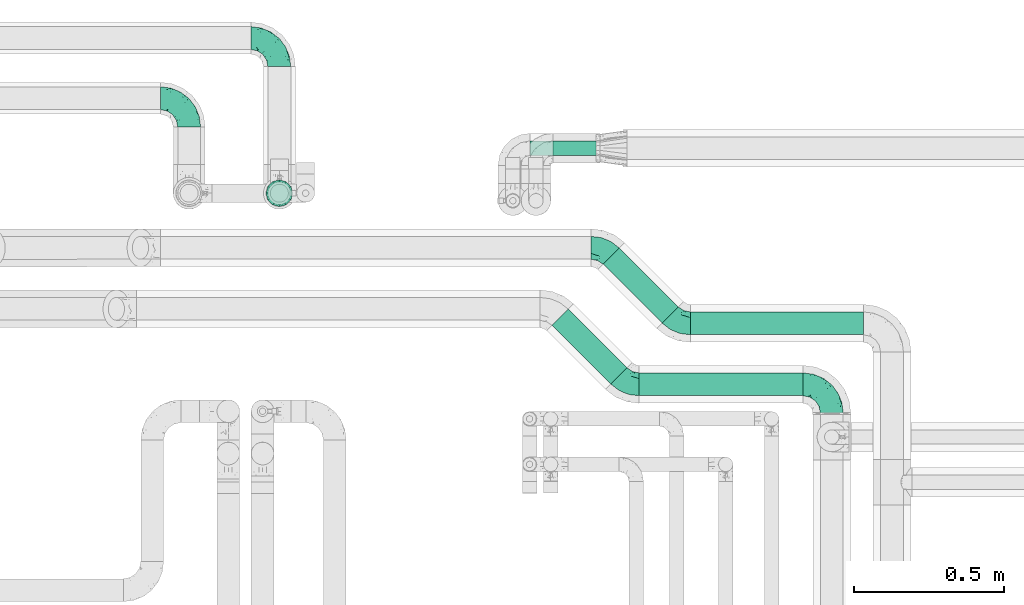
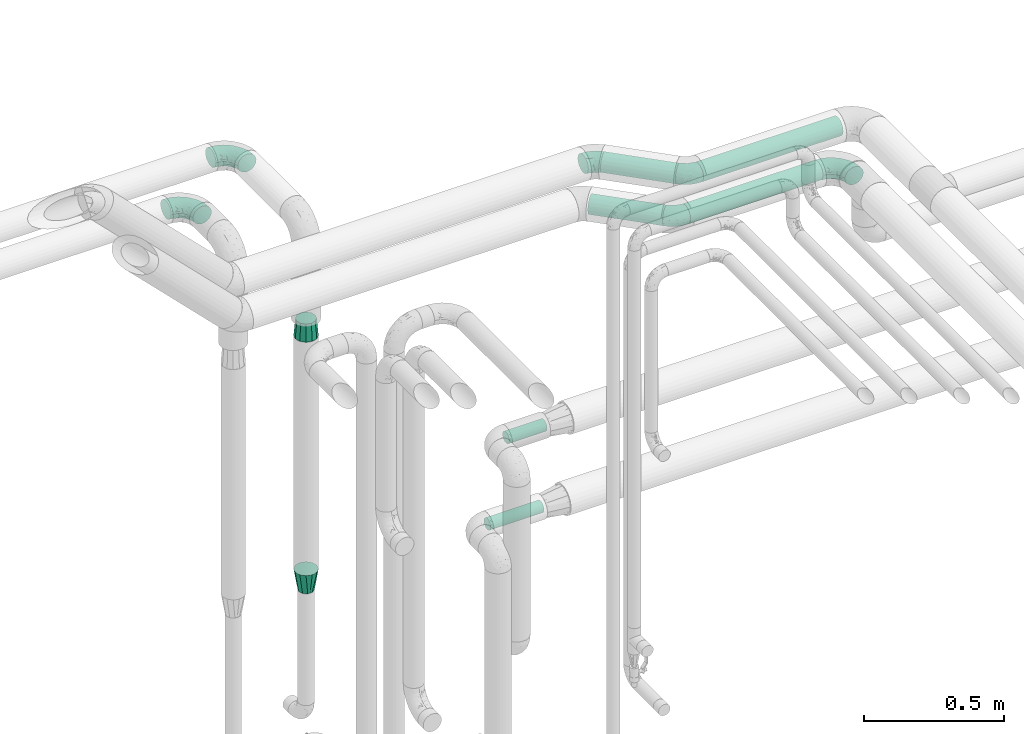
# One storey, part 683 of 824: 8 flow fittings, 6 flow segments.
"""IFC2X3 building model written with IfcOpenShell, lengths in millimetres."""

from ifc_helpers import new_model, entity, si_unit, converted_unit, derived_unit, direction, frame, origin, origin_2d_with_axis, place, context, subcontext, project, spatial, circle, extrude, faceted_brep, source, transform, mapped, material, type_object, type_shapes, element, save


model = new_model("IFC2X3")

# Units and contexts
model_context = context("Model", 3, precision=0.01, world=origin(), true_north=direction((6.12303176911189e-17, 1.0)))
body_context = subcontext(model_context, "Body", "Model", "MODEL_VIEW")
ifc_project = project(units=[si_unit("LENGTHUNIT", "METRE", prefix="MILLI"), si_unit("AREAUNIT", "SQUARE_METRE"), si_unit("VOLUMEUNIT", "CUBIC_METRE"), converted_unit("PLANEANGLEUNIT", "DEGREE", entity("IfcRatioMeasure", 0.0174532925199433), si_unit("PLANEANGLEUNIT", "RADIAN"), dimensions=[0, 0, 0, 0, 0, 0, 0]), si_unit("MASSUNIT", "GRAM", prefix="KILO"), derived_unit("MASSDENSITYUNIT", [(si_unit("MASSUNIT", "GRAM", prefix="KILO"), 1), (si_unit("LENGTHUNIT", "METRE"), -3)]), derived_unit("MOMENTOFINERTIAUNIT", [(si_unit("LENGTHUNIT", "METRE"), 4)]), si_unit("TIMEUNIT", "SECOND"), si_unit("FREQUENCYUNIT", "HERTZ"), si_unit("THERMODYNAMICTEMPERATUREUNIT", "DEGREE_CELSIUS"), derived_unit("THERMALTRANSMITTANCEUNIT", [(si_unit("MASSUNIT", "GRAM", prefix="KILO"), 1), (si_unit("THERMODYNAMICTEMPERATUREUNIT", "KELVIN"), -1), (si_unit("TIMEUNIT", "SECOND"), -3)]), derived_unit("VOLUMETRICFLOWRATEUNIT", [(si_unit("LENGTHUNIT", "METRE"), 3), (si_unit("TIMEUNIT", "SECOND"), -1)]), derived_unit("MASSFLOWRATEUNIT", [(si_unit("MASSUNIT", "GRAM", prefix="KILO"), 1), (si_unit("TIMEUNIT", "SECOND"), -1)]), derived_unit("ROTATIONALFREQUENCYUNIT", [(si_unit("TIMEUNIT", "SECOND"), -1)]), si_unit("ELECTRICCURRENTUNIT", "AMPERE"), si_unit("ELECTRICVOLTAGEUNIT", "VOLT"), si_unit("POWERUNIT", "WATT"), si_unit("FORCEUNIT", "NEWTON", prefix="KILO"), si_unit("ILLUMINANCEUNIT", "LUX"), si_unit("LUMINOUSFLUXUNIT", "LUMEN"), si_unit("LUMINOUSINTENSITYUNIT", "CANDELA"), derived_unit("USERDEFINED", [(si_unit("MASSUNIT", "GRAM", prefix="KILO"), -1), (si_unit("LENGTHUNIT", "METRE"), -2), (si_unit("TIMEUNIT", "SECOND"), 3), (si_unit("LUMINOUSFLUXUNIT", "LUMEN"), 1)]), derived_unit("LINEARVELOCITYUNIT", [(si_unit("LENGTHUNIT", "METRE"), 1), (si_unit("TIMEUNIT", "SECOND"), -1)]), si_unit("PRESSUREUNIT", "PASCAL"), derived_unit("USERDEFINED", [(si_unit("LENGTHUNIT", "METRE"), -2), (si_unit("MASSUNIT", "GRAM", prefix="KILO"), 1), (si_unit("TIMEUNIT", "SECOND"), -2)]), derived_unit("LINEARFORCEUNIT", [(si_unit("MASSUNIT", "GRAM", prefix="KILO"), 1), (si_unit("LENGTHUNIT", "METRE"), 1), (si_unit("TIMEUNIT", "SECOND"), -2), (si_unit("LENGTHUNIT", "METRE"), -1)]), derived_unit("PLANARFORCEUNIT", [(si_unit("MASSUNIT", "GRAM", prefix="KILO"), 1), (si_unit("LENGTHUNIT", "METRE"), 1), (si_unit("TIMEUNIT", "SECOND"), -2), (si_unit("LENGTHUNIT", "METRE"), -2)])], contexts=[model_context])

# Site, building, storey
site_placement = place(None, origin())
site = spatial("IfcSite", under=ifc_project, at=site_placement, CompositionType="ELEMENT")
building_placement = place(site_placement, origin())
building = spatial("IfcBuilding", under=site, at=building_placement, CompositionType="ELEMENT")
storey_placement = place(building_placement, frame((0.0, 0.0, 28200.0)))
storey = spatial("IfcBuildingStorey", under=building, at=storey_placement, CompositionType="ELEMENT", Elevation=28200.0)

# Flow segments
pipe_segment_type = type_object("IfcPipeSegmentType", PredefinedType="NOTDEFINED")
flow_segment_1_placement = place(storey_placement, frame((48004.19, 18316.33, 2960.65)))
element("IfcFlowSegment", 1, at=flow_segment_1_placement, inside=storey, type_object=pipe_segment_type, context=body_context, shape_type="SweptSolid", body=[
    extrude(circle(Radius=37.75, at=origin_2d_with_axis()), frame((0.0, 39.35, 39.35), z_axis=(1.0, 0.0, 0.0), x_axis=(0.0, 1.0, 0.0)), (0.0, 0.0, 1.0), 545.649711574547),
])
flow_segment_2_placement = place(storey_placement, frame((47713.36, 18355.21, 2960.65)))
element("IfcFlowSegment", 2, at=flow_segment_2_placement, inside=storey, type_object=pipe_segment_type, context=body_context, shape_type="SweptSolid", body=[
    extrude(circle(Radius=37.75, at=origin_2d_with_axis()), frame((28.29, 223.66, 39.35), z_axis=(0.707106781186555, -0.70710678118654, 0.0), x_axis=(0.70710678118654, 0.707106781186555, 0.0)), (0.0, 0.0, 1.0), 276.299423149123),
])
flow_segment_3_placement = place(storey_placement, frame((48174.38, 18519.16, 2960.65)))
element("IfcFlowSegment", 3, at=flow_segment_3_placement, inside=storey, type_object=pipe_segment_type, context=body_context, shape_type="SweptSolid", body=[
    extrude(circle(Radius=37.75, at=origin_2d_with_axis()), frame((0.0, 39.35, 39.35), z_axis=(1.0, 0.0, 0.0), x_axis=(0.0, 1.0, 0.0)), (0.0, 0.0, 1.0), 575.649711574558),
])
flow_segment_4_placement = place(storey_placement, frame((47883.25, 18558.04, 2960.65)))
element("IfcFlowSegment", 4, at=flow_segment_4_placement, inside=storey, type_object=pipe_segment_type, context=body_context, shape_type="SweptSolid", body=[
    extrude(circle(Radius=37.75, at=origin_2d_with_axis()), frame((28.29, 223.96, 39.35), z_axis=(0.707106781186485, -0.70710678118661, 0.0), x_axis=(0.70710678118661, 0.707106781186485, 0.0)), (0.0, 0.0, 1.0), 276.715492530283),
])
flow_segment_5_placement = place(storey_placement, frame((47641.3, 19115.63, 1274.4)))
element("IfcFlowSegment", 5, at=flow_segment_5_placement, inside=storey, type_object=pipe_segment_type, context=body_context, shape_type="SweptSolid", body=[
    extrude(circle(Radius=24.0, at=origin_2d_with_axis()), frame((0.0, 25.6, 25.6), z_axis=(1.0, 0.0, 0.0), x_axis=(0.0, 1.0, 0.0)), (0.0, 0.0, 1.0), 220.000000000002),
])
flow_segment_6_placement = place(storey_placement, frame((47718.17, 19115.63, 1624.4)))
element("IfcFlowSegment", 6, at=flow_segment_6_placement, inside=storey, type_object=pipe_segment_type, context=body_context, shape_type="SweptSolid", body=[
    extrude(circle(Radius=24.0, at=origin_2d_with_axis()), frame((0.0, 25.6, 25.6), z_axis=(1.0, 0.0, 0.0), x_axis=(0.0, 1.0, 0.0)), (0.0, 0.0, 1.0), 156.125000000036),
])

# Flow fittings
ifc_material = material()
pipe_fitting_type_1 = type_object("IfcPipeFittingType", PredefinedType="NOTDEFINED", material=ifc_material)
shared_shape_1 = source(origin(), body_context, "Body", "Brep", [
    faceted_brep([(-95.0, 19.02, -32.95), (-95.0, 9.85, -36.75), (-95.0, 0.0, -38.05), (-95.0, -9.85, -36.75), (-95.0, -19.03, -32.95), (-95.0, -26.91, -26.91), (-95.0, -32.95, -19.03), (-95.0, -36.75, -9.85), (-95.0, -38.05, 0.0), (-95.0, -36.75, 9.85), (-95.0, -32.95, 19.02), (-95.0, -26.91, 26.91), (-95.0, -19.03, 32.95), (-95.0, -9.85, 36.75), (-95.0, 0.0, 38.05), (-95.0, 9.85, 36.75), (-95.0, 19.02, 32.95), (-95.0, 26.91, 26.91), (-95.0, 32.95, 19.02), (-95.0, 36.75, 9.85), (-95.0, 38.05, 0.0), (-95.0, 36.75, -9.85), (-95.0, 32.95, -19.03), (-95.0, 26.91, -26.91), (0.0, 95.0, -38.05), (-9.85, 95.0, -36.75), (-19.02, 95.0, -32.95), (-26.91, 95.0, -26.91), (-32.95, 95.0, -19.03), (-36.75, 95.0, -9.85), (-38.05, 95.0, 0.0), (-36.75, 95.0, 9.85), (-32.95, 95.0, 19.02), (-26.91, 95.0, 26.91), (-19.02, 95.0, 32.95), (-9.85, 95.0, 36.75), (0.0, 95.0, 38.05), (9.85, 95.0, 36.75), (19.03, 95.0, 32.95), (26.91, 95.0, 26.91), (32.95, 95.0, 19.02), (36.75, 95.0, 9.85), (38.05, 95.0, 0.0), (36.75, 95.0, -9.85), (32.95, 95.0, -19.03), (26.91, 95.0, -26.91), (19.03, 95.0, -32.95), (9.85, 95.0, -36.75), (-7.99, -4.96, 6.3), (-0.92, 0.92, 0.0), (4.62, 8.1, 8.01), (-76.19, -35.57, 0.0), (-64.32, -32.32, 12.43), (20.51, 62.45, 28.68), (-60.56, -33.52, 0.0), (-70.4, -13.47, 34.42), (-39.61, -5.88, 32.32), (-49.6, 2.07, 37.1), (-70.34, -28.81, 21.71), (14.64, 40.81, 26.5), (5.88, 39.61, 32.32), (3.59, 20.77, 25.31), (-40.45, 68.06, 16.75), (-62.45, -20.51, 28.68), (-44.52, -26.87, 0.0), (-28.47, -20.22, 0.0), (-26.43, -17.83, 8.75), (-76.1, 39.63, 10.76), (-72.74, 37.58, 18.19), (-60.35, 46.18, 14.61), (-13.4, 13.4, 32.12), (-20.77, -3.59, 25.31), (-14.66, 81.47, 35.56), (-6.22, 71.26, 37.92), (-57.5, 42.48, 22.79), (-15.0, 34.74, 37.7), (-27.1, 12.08, 36.05), (-9.2, 28.81, 35.63), (-79.98, 23.7, 30.95), (-73.68, -4.3, 37.48), (-30.74, 21.67, 37.97), (-62.36, 47.59, 6.79), (-72.71, 32.83, 24.69), (-67.42, 7.02, 37.95), (-32.13, 75.27, 24.51), (-43.46, 51.47, 26.26), (-24.98, 73.15, 31.29), (20.59, 41.28, 19.85), (7.79, 16.09, 15.86), (-73.21, 42.39, 0.0), (-54.73, 54.73, 0.0), (-73.44, 15.79, 35.79), (-5.94, 4.32, 20.43), (28.81, 70.34, 21.71), (32.32, 64.32, 12.43), (-53.59, 26.2, 35.09), (-52.02, 19.31, 37.21), (21.38, 33.53, 10.34), (26.87, 44.52, 0.0), (-48.28, 12.14, 38.05), (4.3, 73.68, 37.48), (-44.08, -25.52, 12.79), (-41.28, -20.59, 19.85), (35.57, 76.19, 0.0), (-47.26, 54.3, 20.18), (-47.4, 61.99, 8.58), (-42.39, 73.21, 0.0), (-39.67, 78.86, 7.21), (-45.69, 36.84, 33.11), (-32.83, 50.13, 33.35), (13.47, 70.4, 34.42), (-18.25, 63.73, 36.07), (-40.63, -13.75, 27.22), (-16.63, 46.37, 37.95), (-53.47, 38.79, 28.59), (-26.07, 48.54, 36.15), (-34.51, 34.51, 36.86), (-2.07, 49.6, 37.1), (-22.79, -10.49, 19.23), (-61.73, 28.67, 31.87), (9.65, 14.7, 0.0), (20.22, 28.47, 0.0), (33.52, 60.56, 0.0), (-11.42, -5.44, 13.25), (-14.7, -9.65, 0.0), (-81.47, 14.66, -35.56), (-62.45, -20.51, -28.68), (-71.26, 6.22, -37.92), (-75.27, 32.13, -24.51), (-73.15, 24.98, -31.29), (13.47, 70.4, -34.42), (5.88, 39.61, -32.32), (-2.07, 49.6, -37.1), (-78.86, 39.67, -7.21), (-70.4, -13.47, -34.42), (-39.61, -5.88, -32.32), (-61.99, 47.4, -8.58), (32.32, 64.32, -12.43), (28.81, 70.34, -21.71), (-63.73, 18.25, -36.07), (-50.13, 32.83, -33.35), (4.3, 73.68, -37.48), (-7.02, 67.42, -37.95), (-39.63, 76.1, -10.76), (-46.18, 60.35, -14.61), (-47.59, 62.36, -6.79), (-64.32, -32.32, -12.43), (-26.2, 53.59, -35.09), (-15.79, 73.44, -35.79), (-19.31, 52.02, -37.21), (-37.58, 72.74, -18.19), (-70.34, -28.81, -21.71), (-42.48, 57.5, -22.79), (-38.79, 53.47, -28.59), (-51.47, 43.46, -26.26), (-32.83, 72.71, -24.69), (-46.37, 16.63, -37.95), (-73.68, -4.3, -37.48), (-41.28, -20.59, -19.85), (-44.08, -25.52, -12.79), (13.75, 40.63, -27.22), (20.51, 62.45, -28.68), (-68.06, 40.45, -16.75), (-54.3, 47.26, -20.18), (-12.14, 48.28, -38.05), (-21.67, 30.74, -37.97), (-36.84, 45.69, -33.11), (-11.42, -5.44, -13.25), (7.79, 16.09, -15.86), (4.62, 8.1, -8.01), (-23.7, 79.98, -30.95), (-26.43, -17.83, -8.75), (-7.99, -4.96, -6.3), (-40.81, -14.64, -26.5), (-20.77, -3.59, -25.31), (-34.74, 15.0, -37.7), (-12.08, 27.1, -36.05), (-28.81, 9.2, -35.63), (-22.79, -10.49, -19.23), (21.38, 33.53, -10.34), (20.59, 41.28, -19.85), (-48.54, 26.07, -36.15), (-49.6, 2.07, -37.1), (-13.4, 13.4, -32.12), (3.59, 20.77, -25.31), (-28.67, 61.73, -31.87), (-34.51, 34.51, -36.86), (-5.94, 4.32, -20.43)], [[[0, 1, 2, 3, 4, 5, 6, 7, 8, 9, 10, 11, 12, 13, 14, 15, 16, 17, 18, 19, 20, 21, 22, 23]], [[24, 25, 26, 27, 28, 29, 30, 31, 32, 33, 34, 35, 36, 37, 38, 39, 40, 41, 42, 43, 44, 45, 46, 47]], [[48, 49, 50]], [[51, 52, 9]], [[53, 39, 38]], [[9, 52, 10]], [[54, 52, 51]], [[55, 56, 57]], [[11, 10, 58]], [[59, 60, 61]], [[32, 31, 62]], [[63, 12, 11]], [[63, 55, 12]], [[64, 65, 66]], [[67, 68, 69]], [[70, 56, 71]], [[35, 72, 73]], [[69, 68, 74]], [[75, 76, 77]], [[16, 78, 17]], [[13, 79, 14]], [[76, 75, 80]], [[67, 69, 81]], [[18, 17, 82]], [[14, 79, 83]], [[20, 19, 67]], [[84, 85, 86]], [[87, 61, 88]], [[89, 81, 90]], [[18, 82, 68]], [[15, 91, 16]], [[14, 83, 15]], [[71, 92, 61]], [[17, 78, 82]], [[93, 87, 94]], [[95, 91, 96]], [[97, 98, 94]], [[86, 72, 34]], [[96, 99, 80]], [[37, 36, 100]], [[40, 39, 93]], [[40, 94, 41]], [[64, 66, 101]], [[93, 94, 40]], [[58, 102, 63]], [[94, 103, 41]], [[94, 87, 97]], [[104, 69, 74]], [[34, 33, 86]], [[105, 69, 104]], [[52, 58, 10]], [[106, 107, 30]], [[108, 109, 85]], [[105, 106, 90]], [[53, 110, 60]], [[86, 111, 72]], [[86, 109, 111]], [[33, 84, 86]], [[12, 55, 13]], [[112, 56, 63]], [[110, 38, 37]], [[34, 72, 35]], [[36, 35, 73]], [[111, 113, 73]], [[105, 107, 106]], [[110, 53, 38]], [[74, 114, 85]], [[91, 15, 83]], [[105, 90, 81]], [[107, 62, 31]], [[33, 32, 84]], [[115, 109, 116]], [[111, 115, 113]], [[100, 73, 117]], [[56, 55, 63]], [[79, 55, 57]], [[102, 118, 112]], [[56, 70, 76]], [[100, 110, 37]], [[117, 77, 60]], [[117, 60, 110]], [[60, 70, 61]], [[58, 52, 101]], [[63, 11, 58]], [[39, 53, 93]], [[87, 93, 53]], [[96, 91, 83]], [[78, 91, 119]], [[32, 62, 84]], [[84, 62, 104]], [[86, 85, 109]], [[85, 114, 108]], [[80, 113, 116]], [[117, 73, 113]], [[80, 116, 96]], [[80, 57, 76]], [[71, 112, 118]], [[61, 87, 59]], [[62, 107, 105]], [[97, 120, 121]], [[70, 71, 61]], [[71, 118, 92]], [[73, 100, 36]], [[110, 100, 117]], [[55, 79, 13]], [[83, 79, 57]], [[96, 83, 99]], [[116, 108, 95]], [[50, 97, 88]], [[97, 87, 88]], [[50, 49, 120]], [[122, 94, 98]], [[89, 20, 67]], [[105, 81, 69]], [[89, 67, 81]], [[68, 19, 18]], [[68, 67, 19]], [[74, 68, 82]], [[114, 82, 119]], [[74, 85, 104]], [[82, 114, 74]], [[114, 119, 108]], [[95, 108, 119]], [[116, 109, 108]], [[123, 48, 50]], [[97, 50, 120]], [[123, 50, 88]], [[91, 95, 119]], [[116, 95, 96]], [[84, 104, 85]], [[104, 62, 105]], [[83, 57, 99]], [[57, 80, 99]], [[66, 48, 123]], [[66, 124, 48]], [[118, 66, 123]], [[124, 66, 65]], [[66, 118, 101]], [[54, 64, 52]], [[124, 49, 48]], [[30, 107, 31]], [[91, 78, 16]], [[82, 78, 119]], [[56, 76, 57]], [[77, 76, 70]], [[60, 77, 70]], [[77, 117, 75]], [[117, 113, 75]], [[113, 80, 75]], [[9, 8, 51]], [[103, 94, 122]], [[103, 42, 41]], [[73, 72, 111]], [[113, 115, 116]], [[111, 109, 115]], [[102, 112, 63]], [[71, 56, 112]], [[118, 102, 101]], [[92, 123, 88]], [[123, 92, 118]], [[61, 92, 88]], [[87, 53, 59]], [[60, 59, 53]], [[97, 121, 98]], [[58, 101, 102]], [[64, 101, 52]], [[125, 1, 0]], [[126, 5, 4]], [[2, 1, 127]], [[1, 125, 127]], [[128, 129, 23]], [[130, 131, 132]], [[89, 133, 20]], [[126, 134, 135]], [[136, 89, 90]], [[137, 138, 44]], [[139, 129, 140]], [[24, 141, 142]], [[143, 144, 145]], [[125, 129, 139]], [[6, 146, 7]], [[147, 148, 149]], [[146, 51, 7]], [[143, 150, 144]], [[146, 6, 151]], [[152, 153, 154]], [[126, 4, 134]], [[0, 23, 129]], [[28, 155, 150]], [[43, 42, 103]], [[54, 146, 64]], [[139, 156, 127]], [[157, 3, 2]], [[151, 158, 159]], [[160, 131, 161]], [[22, 21, 162]], [[136, 144, 163]], [[149, 164, 165]], [[24, 142, 25]], [[166, 140, 154]], [[154, 129, 128]], [[143, 30, 29]], [[167, 168, 169]], [[155, 28, 27]], [[26, 170, 27]], [[171, 167, 172]], [[26, 25, 148]], [[27, 170, 155]], [[173, 135, 174]], [[144, 150, 152]], [[175, 176, 177]], [[24, 47, 141]], [[45, 161, 46]], [[148, 25, 142]], [[176, 175, 165]], [[64, 159, 171]], [[138, 45, 44]], [[130, 46, 161]], [[137, 44, 43]], [[178, 159, 158]], [[137, 103, 122]], [[163, 144, 152]], [[136, 133, 89]], [[103, 137, 43]], [[6, 5, 151]], [[178, 158, 173]], [[134, 4, 3]], [[178, 173, 174]], [[137, 98, 179]], [[145, 90, 106]], [[138, 180, 161]], [[46, 130, 47]], [[136, 90, 145]], [[133, 162, 21]], [[23, 22, 128]], [[139, 140, 181]], [[139, 181, 156]], [[157, 127, 182]], [[157, 134, 3]], [[182, 177, 135]], [[182, 135, 134]], [[135, 183, 174]], [[131, 130, 161]], [[141, 130, 132]], [[160, 180, 184]], [[131, 183, 176]], [[5, 126, 151]], [[158, 151, 126]], [[180, 138, 137]], [[161, 45, 138]], [[149, 148, 142]], [[170, 148, 185]], [[22, 162, 128]], [[128, 162, 163]], [[129, 154, 140]], [[154, 153, 166]], [[165, 156, 186]], [[182, 127, 156]], [[165, 186, 149]], [[165, 132, 176]], [[131, 184, 183]], [[187, 167, 178]], [[184, 168, 187]], [[167, 169, 172]], [[184, 180, 168]], [[174, 183, 184]], [[127, 157, 2]], [[134, 157, 182]], [[130, 141, 47]], [[142, 141, 132]], [[149, 142, 164]], [[186, 166, 147]], [[180, 179, 168]], [[169, 179, 120]], [[137, 179, 180]], [[179, 121, 120]], [[106, 30, 143]], [[136, 145, 144]], [[106, 143, 145]], [[150, 29, 28]], [[150, 143, 29]], [[152, 150, 155]], [[153, 155, 185]], [[152, 154, 163]], [[155, 153, 152]], [[153, 185, 166]], [[147, 166, 185]], [[186, 140, 166]], [[169, 120, 49]], [[169, 49, 172]], [[179, 169, 168]], [[148, 147, 185]], [[186, 147, 149]], [[128, 163, 154]], [[163, 162, 136]], [[142, 132, 164]], [[132, 165, 164]], [[171, 124, 65]], [[124, 171, 172]], [[64, 146, 159]], [[171, 159, 178]], [[171, 65, 64]], [[172, 49, 124]], [[162, 133, 136]], [[20, 133, 21]], [[148, 170, 26]], [[155, 170, 185]], [[131, 176, 132]], [[177, 176, 183]], [[135, 177, 183]], [[177, 182, 175]], [[182, 156, 175]], [[156, 165, 175]], [[51, 146, 54]], [[51, 8, 7]], [[129, 125, 0]], [[127, 125, 139]], [[140, 186, 181]], [[156, 181, 186]], [[158, 126, 173]], [[135, 173, 126]], [[187, 178, 174]], [[171, 178, 167]], [[184, 187, 174]], [[167, 187, 168]], [[180, 160, 161]], [[184, 131, 160]], [[98, 137, 122]], [[98, 121, 179]], [[151, 159, 146]]]),
])
type_shapes(pipe_fitting_type_1, [shared_shape_1])
for number, where, z_axis, x_axis in (
    (7, (48644.84, 18355.68, 3000.0), (0.0, 0.0, 1.0), (0.0, 1.0, 0.0)),
    (8, (46807.82, 19507.23, 3000.0), (0.0, 0.0, 1.0), (0.0, 1.0, 0.0)),
    (9, (46507.82, 19307.23, 3000.0), (0.0, 0.0, 1.0), (0.0, 1.0, 0.0)),
):
    element("IfcFlowFitting", number, at=place(storey_placement, frame(where, z_axis=z_axis, x_axis=x_axis)), inside=storey, type_object=pipe_fitting_type_1, material=ifc_material, context=body_context, shape_type="MappedRepresentation", body=[
        mapped(shared_shape_1, transform((0.0, 0.0, 0.0), scale=1.0)),
    ])
pipe_fitting_type_2 = type_object("IfcPipeFittingType", PredefinedType="NOTDEFINED", material=ifc_material)
shared_shape_2 = source(origin(), body_context, "Body", "Brep", [
    faceted_brep([(-39.35, 19.02, -32.95), (-39.35, 9.85, -36.75), (-39.35, 0.0, -38.05), (-39.35, -9.85, -36.75), (-39.35, -19.03, -32.95), (-39.35, -26.91, -26.91), (-39.35, -32.95, -19.03), (-39.35, -36.75, -9.85), (-39.35, -38.05, 0.0), (-39.35, -36.75, 9.85), (-39.35, -32.95, 19.02), (-39.35, -26.91, 26.91), (-39.35, -19.03, 32.95), (-39.35, -9.85, 36.75), (-39.35, 0.0, 38.05), (-39.35, 9.85, 36.75), (-39.35, 19.02, 32.95), (-39.35, 26.91, 26.91), (-39.35, 32.95, 19.02), (-39.35, 36.75, 9.85), (-39.35, 38.05, 0.0), (-39.35, 36.75, -9.85), (-39.35, 32.95, -19.03), (-39.35, 26.91, -26.91), (27.82, 27.82, -38.05), (20.86, 34.79, -36.75), (14.37, 41.28, -32.95), (8.8, 46.85, -26.91), (4.52, 51.13, -19.03), (1.84, 53.81, -9.85), (0.92, 54.73, 0.0), (1.84, 53.81, 9.85), (4.52, 51.13, 19.02), (8.8, 46.85, 26.91), (14.37, 41.28, 32.95), (20.86, 34.79, 36.75), (27.82, 27.82, 38.05), (34.79, 20.86, 36.75), (41.28, 14.37, 32.95), (46.85, 8.8, 26.91), (51.13, 4.52, 19.02), (53.81, 1.84, 9.85), (54.73, 0.92, 0.0), (53.81, 1.84, -9.85), (51.13, 4.52, -19.03), (46.85, 8.8, -26.91), (41.28, 14.37, -32.95), (34.79, 20.86, -36.75), (-16.48, -28.6, 22.48), (-9.83, -32.19, 13.52), (8.97, -21.66, 21.67), (-20.54, -35.57, 0.0), (-4.91, -33.52, 0.0), (-13.54, -34.93, 6.65), (-11.41, -20.66, 29.54), (31.88, -8.57, 22.48), (-19.69, -13.48, 34.86), (3.15, -7.61, 34.49), (12.7, 20.76, 37.8), (-14.37, -2.8, 37.58), (-4.35, 10.49, 37.89), (-23.66, 5.7, 37.8), (22.68, -6.54, 29.54), (23.46, 4.39, 34.86), (-17.67, 16.65, 35.5), (-11.48, 27.71, 30.93), (-5.05, 36.47, 26.65), (11.57, -24.66, 14.82), (11.29, -27.26, 7.35), (-19.91, 32.6, 23.86), (-16.29, 39.33, 15.52), (34.27, -15.12, 6.65), (39.68, -10.63, 0.0), (-13.09, 43.52, 7.94), (12.14, 8.18, 37.58), (29.72, -15.81, 13.52), (2.92, 25.68, 35.46), (5.55, -13.39, 30.82), (-17.56, 42.39, 0.0), (-7.75, 40.18, 21.01), (11.13, -26.87, 0.0), (27.17, -20.22, 0.0), (-14.37, -2.8, -37.58), (-13.54, -34.93, -6.65), (11.26, -27.2, -7.7), (0.72, 24.27, -35.5), (-23.66, 5.7, -37.8), (-21.52, 40.03, -7.94), (-16.29, 39.33, -15.52), (22.68, -6.54, -29.54), (-22.21, 29.36, -26.65), (29.72, -15.81, -13.52), (-22.93, 33.89, -21.01), (-8.97, 37.13, -23.86), (12.14, 8.18, -37.58), (-20.22, 16.09, -35.46), (-9.83, -32.19, -13.52), (31.88, -8.57, -22.48), (-16.48, -28.6, -22.48), (8.97, -21.66, -21.67), (8.74, -25.75, -14.99), (-11.41, -20.66, -29.54), (5.55, -13.39, -30.82), (3.15, -7.61, -34.49), (-19.69, -13.48, -34.86), (-11.48, 27.71, -30.93), (34.27, -15.12, -6.65), (12.7, 20.76, -37.8), (23.46, 4.39, -34.86), (-4.35, 10.49, -37.89)], [[[0, 1, 2, 3, 4, 5, 6, 7, 8, 9, 10, 11, 12, 13, 14, 15, 16, 17, 18, 19, 20, 21, 22, 23]], [[24, 25, 26, 27, 28, 29, 30, 31, 32, 33, 34, 35, 36, 37, 38, 39, 40, 41, 42, 43, 44, 45, 46, 47]], [[48, 49, 50]], [[51, 52, 53]], [[12, 11, 54]], [[40, 39, 55]], [[56, 54, 57]], [[48, 11, 10]], [[36, 35, 58]], [[13, 12, 56]], [[59, 60, 61]], [[14, 13, 59]], [[62, 55, 39]], [[38, 37, 63]], [[61, 15, 14]], [[16, 64, 65]], [[9, 51, 53]], [[33, 66, 34]], [[67, 49, 68]], [[65, 17, 16]], [[18, 17, 69]], [[18, 69, 70]], [[19, 18, 70]], [[41, 71, 72]], [[73, 20, 19]], [[52, 68, 53]], [[49, 53, 68]], [[16, 15, 64]], [[36, 58, 74]], [[39, 38, 62]], [[57, 74, 59]], [[74, 37, 36]], [[66, 69, 65]], [[75, 40, 55]], [[60, 58, 76]], [[62, 38, 63]], [[17, 65, 69]], [[71, 41, 75]], [[49, 48, 10]], [[61, 64, 15]], [[77, 50, 62]], [[19, 70, 73]], [[10, 9, 49]], [[78, 73, 30]], [[48, 54, 11]], [[31, 73, 70]], [[57, 63, 74]], [[69, 66, 79]], [[55, 62, 50]], [[79, 70, 69]], [[56, 59, 13]], [[35, 34, 76]], [[76, 65, 64]], [[54, 77, 57]], [[60, 59, 74]], [[75, 41, 40]], [[54, 48, 50]], [[32, 31, 70]], [[75, 55, 50]], [[65, 76, 34]], [[60, 76, 64]], [[54, 56, 12]], [[59, 56, 57]], [[74, 63, 37]], [[62, 63, 57]], [[9, 8, 51]], [[68, 52, 80, 81]], [[9, 53, 49]], [[71, 68, 81]], [[68, 75, 67]], [[72, 71, 81]], [[72, 42, 41]], [[68, 71, 75]], [[59, 61, 14]], [[64, 61, 60]], [[76, 58, 35]], [[74, 58, 60]], [[30, 73, 31]], [[73, 78, 20]], [[50, 77, 54]], [[62, 57, 77]], [[34, 66, 65]], [[79, 33, 32]], [[33, 79, 66]], [[32, 70, 79]], [[75, 50, 67]], [[49, 67, 50]], [[3, 2, 82]], [[52, 83, 84]], [[26, 25, 85]], [[2, 1, 86]], [[21, 87, 88]], [[46, 45, 89]], [[0, 23, 90]], [[44, 43, 91]], [[92, 88, 93]], [[24, 47, 94]], [[29, 28, 88]], [[1, 0, 95]], [[83, 7, 96]], [[91, 97, 44]], [[98, 99, 100]], [[98, 96, 6]], [[5, 4, 101]], [[89, 102, 103]], [[7, 6, 96]], [[5, 98, 6]], [[104, 4, 3]], [[90, 93, 105]], [[101, 98, 5]], [[28, 27, 93]], [[20, 78, 87]], [[27, 105, 93]], [[30, 29, 87]], [[102, 99, 101]], [[105, 85, 95]], [[88, 22, 21]], [[28, 93, 88]], [[104, 101, 4]], [[85, 105, 26]], [[90, 92, 93]], [[86, 82, 2]], [[27, 26, 105]], [[43, 72, 106]], [[107, 25, 24]], [[108, 47, 46]], [[7, 83, 51]], [[44, 97, 45]], [[103, 108, 89]], [[97, 89, 45]], [[109, 107, 94]], [[99, 97, 91]], [[109, 94, 82]], [[106, 72, 81]], [[108, 94, 47]], [[103, 104, 82]], [[83, 96, 84]], [[103, 82, 94]], [[100, 91, 84]], [[107, 85, 25]], [[29, 88, 87]], [[109, 86, 95]], [[98, 101, 99]], [[89, 97, 99]], [[105, 95, 0]], [[109, 95, 85]], [[82, 104, 3]], [[101, 104, 103]], [[89, 108, 46]], [[94, 108, 103]], [[51, 83, 52]], [[51, 8, 7]], [[100, 84, 96]], [[106, 84, 91]], [[84, 81, 80, 52]], [[43, 42, 72]], [[84, 106, 81]], [[43, 106, 91]], [[95, 86, 1]], [[82, 86, 109]], [[94, 107, 24]], [[85, 107, 109]], [[20, 87, 21]], [[87, 78, 30]], [[99, 102, 89]], [[101, 103, 102]], [[0, 90, 105]], [[92, 23, 22]], [[23, 92, 90]], [[22, 88, 92]], [[98, 100, 96]], [[91, 100, 99]]]),
])
type_shapes(pipe_fitting_type_2, [shared_shape_2])
for number, where, z_axis, x_axis in (
    (10, (47964.84, 18355.68, 3000.0), (0.0, 0.0, 1.0), (0.707106781186551, -0.707106781186544, 0.0)),
    (11, (48135.03, 18558.51, 3000.0), (0.0, 0.0, 1.0), (0.707106781186538, -0.707106781186558, 0.0)),
    (12, (47883.72, 18809.82, 3000.0), (0.0, 0.0, 1.0), (-0.707106781186505, 0.70710678118659, 0.0)),
):
    element("IfcFlowFitting", number, at=place(storey_placement, frame(where, z_axis=z_axis, x_axis=x_axis)), inside=storey, type_object=pipe_fitting_type_2, material=ifc_material, context=body_context, shape_type="MappedRepresentation", body=[
        mapped(shared_shape_2, transform((0.0, 0.0, 0.0), scale=1.0)),
    ])
pipe_fitting_type_3 = type_object("IfcPipeFittingType", PredefinedType="NOTDEFINED", material=ifc_material)
shared_shape_3 = source(origin(), body_context, "Body", "Brep", [
    faceted_brep([(89.0, -44.45, 0.0), (89.0, -42.1, -8.76), (89.0, -38.49, -22.22), (89.0, -30.36, -30.36), (89.0, -22.23, -38.49), (89.0, -11.11, -41.47), (89.0, 0.0, -44.45), (89.0, 11.11, -41.47), (89.0, 22.22, -38.49), (89.0, 30.36, -30.36), (89.0, 38.49, -22.22), (89.0, 42.1, -8.76), (89.0, 44.45, 0.0), (89.0, 42.1, 8.76), (89.0, 38.49, 22.23), (89.0, 30.36, 30.36), (89.0, 22.22, 38.49), (89.0, 11.11, 41.47), (89.0, 0.0, 44.45), (89.0, -11.11, 41.47), (89.0, -22.23, 38.49), (89.0, -30.36, 30.36), (89.0, -38.49, 22.23), (89.0, -42.1, 8.76), (0.0, 30.15, 0.0), (0.0, 27.27, -8.86), (0.0, 24.39, -17.72), (0.0, 16.85, -23.2), (0.0, 9.32, -28.67), (0.0, 0.0, -28.67), (0.0, -9.32, -28.67), (0.0, -16.85, -23.2), (0.0, -24.39, -17.72), (0.0, -27.27, -8.86), (0.0, -30.15, 0.0), (0.0, -27.27, 8.86), (0.0, -24.39, 17.72), (0.0, -16.85, 23.2), (0.0, -9.32, 28.67), (0.0, 0.0, 28.67), (0.0, 9.32, 28.67), (0.0, 16.85, 23.2), (0.0, 24.39, 17.72), (0.0, 27.27, 8.86)], [[[0, 1, 2, 3, 4, 5, 6, 7, 8, 9, 10, 11, 12, 13, 14, 15, 16, 17, 18, 19, 20, 21, 22, 23]], [[24, 25, 26, 27, 28, 29, 30, 31, 32, 33, 34, 35, 36, 37, 38, 39, 40, 41, 42, 43]], [[2, 33, 32]], [[28, 7, 29]], [[29, 5, 30]], [[24, 12, 11]], [[3, 32, 31]], [[34, 1, 0]], [[1, 34, 33]], [[8, 28, 27]], [[2, 1, 33]], [[31, 4, 3]], [[2, 32, 3]], [[11, 25, 24]], [[26, 10, 9]], [[10, 25, 11]], [[28, 8, 7]], [[27, 26, 9]], [[26, 25, 10]], [[31, 30, 4]], [[8, 27, 9]], [[29, 7, 6]], [[5, 29, 6]], [[5, 4, 30]], [[14, 43, 42]], [[38, 19, 39]], [[39, 17, 40]], [[34, 0, 23]], [[15, 42, 41]], [[24, 13, 12]], [[13, 24, 43]], [[20, 38, 37]], [[14, 13, 43]], [[41, 16, 15]], [[14, 42, 15]], [[23, 35, 34]], [[36, 22, 21]], [[22, 35, 23]], [[38, 20, 19]], [[37, 36, 21]], [[36, 35, 22]], [[41, 40, 16]], [[20, 37, 21]], [[39, 19, 18]], [[17, 39, 18]], [[17, 16, 40]]]),
])
type_shapes(pipe_fitting_type_3, [shared_shape_3])
flow_fitting_1_placement = place(storey_placement, frame((46807.82, 18991.22, 1398.88), z_axis=(0.0, -1.0, 0.0), x_axis=(0.0, 0.0, 1.0)))
element("IfcFlowFitting", 13, at=flow_fitting_1_placement, inside=storey, type_object=pipe_fitting_type_3, material=ifc_material, context=body_context, shape_type="MappedRepresentation", body=[
    mapped(shared_shape_3, transform((0.0, 0.0, 0.0), scale=1.0)),
])
pipe_fitting_type_4 = type_object("IfcPipeFittingType", PredefinedType="NOTDEFINED", material=ifc_material)
shared_shape_4 = source(origin(), body_context, "Body", "Brep", [
    faceted_brep([(75.0, 32.91, 19.0), (75.0, 25.95, 25.95), (75.0, 19.0, 32.91), (75.0, 9.5, 35.45), (75.0, 0.0, 38.0), (75.0, -9.5, 35.45), (75.0, -19.0, 32.91), (75.0, -25.95, 25.95), (75.0, -32.91, 19.0), (75.0, -35.45, 9.5), (75.0, -38.0, 0.0), (75.0, -35.45, -9.5), (75.0, -32.91, -19.0), (75.0, -25.95, -25.95), (75.0, -19.0, -32.91), (75.0, -9.5, -35.45), (75.0, 0.0, -38.0), (75.0, 9.5, -35.45), (75.0, 19.0, -32.91), (75.0, 25.95, -25.95), (75.0, 32.91, -19.0), (75.0, 35.45, -9.5), (75.0, 38.0, 0.0), (75.0, 35.45, 9.5), (0.0, 11.12, 41.52), (0.0, 22.25, 38.54), (0.0, 30.39, 30.39), (0.0, 38.54, 22.25), (0.0, 41.52, 11.12), (0.0, 44.5, 0.0), (0.0, 41.52, -11.13), (0.0, 38.54, -22.25), (0.0, 30.39, -30.39), (0.0, 22.25, -38.54), (0.0, 11.12, -41.52), (0.0, 0.0, -44.5), (0.0, -11.13, -41.52), (0.0, -22.25, -38.54), (0.0, -30.39, -30.39), (0.0, -38.54, -22.25), (0.0, -41.52, -11.12), (0.0, -44.5, 0.0), (0.0, -41.52, 11.13), (0.0, -38.54, 22.25), (0.0, -30.39, 30.39), (0.0, -22.25, 38.54), (0.0, -11.12, 41.52), (0.0, 0.0, 44.5)], [[[0, 1, 2, 3, 4, 5, 6, 7, 8, 9, 10, 11, 12, 13, 14, 15, 16, 17, 18, 19, 20, 21, 22, 23]], [[24, 25, 26, 27, 28, 29, 30, 31, 32, 33, 34, 35, 36, 37, 38, 39, 40, 41, 42, 43, 44, 45, 46, 47]], [[21, 20, 31, 30, 29, 22]], [[34, 33, 18, 17, 16, 35]], [[33, 32, 31, 20, 19, 18]], [[36, 35, 16, 15, 14, 37]], [[10, 41, 40, 39, 12, 11]], [[12, 39, 38, 37, 14, 13]], [[9, 8, 43, 42, 41, 10]], [[46, 45, 6, 5, 4, 47]], [[45, 44, 43, 8, 7, 6]], [[24, 47, 4, 3, 2, 25]], [[22, 29, 28, 27, 0, 23]], [[0, 27, 26, 25, 2, 1]]]),
])
type_shapes(pipe_fitting_type_4, [shared_shape_4])
flow_fitting_2_placement = place(storey_placement, frame((46807.82, 18991.22, 2505.0), z_axis=(0.0, -1.0, 0.0), x_axis=(0.0, 0.0, 1.0)))
element("IfcFlowFitting", 14, at=flow_fitting_2_placement, inside=storey, type_object=pipe_fitting_type_4, material=ifc_material, context=body_context, shape_type="MappedRepresentation", body=[
    mapped(shared_shape_4, transform((0.0, 0.0, 0.0), scale=1.0)),
])

save(model, "model.ifc")
